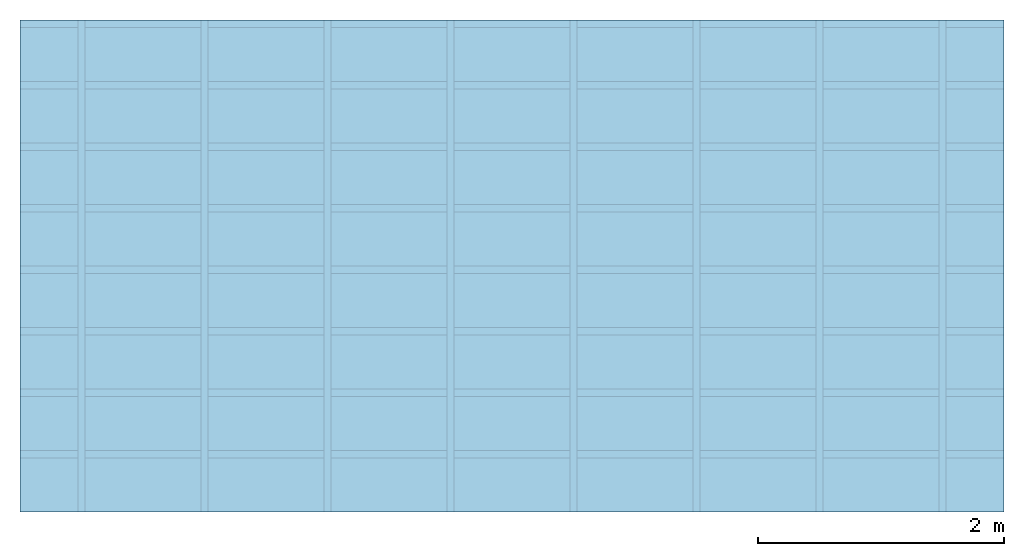
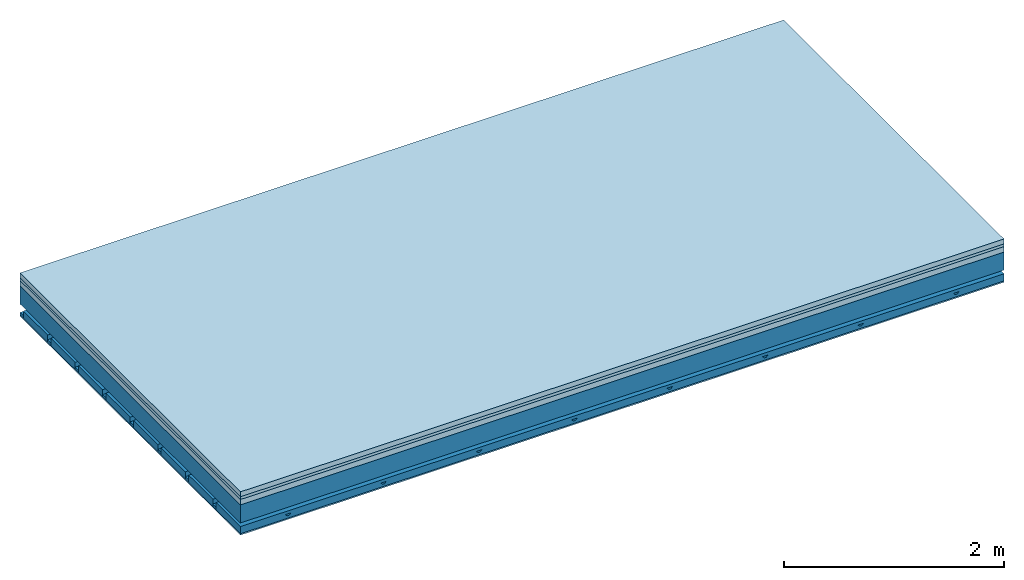
# One storey: 4 members, 4 plates, 1 element without a shape of its own.
"""IFC4 building model written with IfcOpenShell, lengths in metres."""

from ifc_helpers import new_model, si_unit, derived_unit, direction, frame, frame_2d, origin, origin_with_axes, place, context, project, spatial, polyline, rectangle, outline, extrude, material, layer, layer_set, type_object, element, aggregate, save


model = new_model("IFC4")

# Units and contexts
plan_context = context("Plan", 3, precision=1e-05, world=origin(), true_north=direction((0.0, 1.0)))
model_context = context("Model", 3, precision=1e-05, world=origin(), true_north=direction((0.0, 1.0)))
ifc_project = project(units=[si_unit("LENGTHUNIT", "METRE"), derived_unit("SOUNDPRESSUREUNIT", [(si_unit("PRESSUREUNIT", "PASCAL", prefix="MICRO"), 0)]), si_unit("ENERGYUNIT", "JOULE", prefix="MEGA"), si_unit("MASSUNIT", "GRAM", prefix="KILO"), derived_unit("THERMALTRANSMITTANCEUNIT", [(si_unit("POWERUNIT", "WATT"), 1), (si_unit("AREAUNIT", "SQUARE_METRE"), -1), (si_unit("THERMODYNAMICTEMPERATUREUNIT", "KELVIN"), -1)]), derived_unit("AREADENSITYUNIT", [(si_unit("MASSUNIT", "GRAM", prefix="KILO"), 1), (si_unit("AREAUNIT", "SQUARE_METRE"), -1)]), derived_unit("USERDEFINED", [(si_unit("ENERGYUNIT", "JOULE", prefix="MEGA"), 1), (si_unit("AREAUNIT", "SQUARE_METRE"), -1)])], contexts=[plan_context, model_context])

# Site, building, storey
site = spatial("IfcSite", under=ifc_project)
building_placement = place(None, origin())
building = spatial("IfcBuilding", under=site, at=building_placement)
storey_placement = place(building_placement, origin())
storey = spatial("IfcBuildingStorey", under=building, at=storey_placement)

# Slab, members, plates
ifc_material_1 = material(Category="04.005")
ifc_layer_1 = layer(ifc_material_1, 0.055, Name="On-material")
ifc_material_2 = material()
ifc_layer_2 = layer(ifc_material_2, 0.03, Name="Impact sound insulation")
ifc_material_3 = material(Category="03.011")
ifc_layer_3 = layer(ifc_material_3, 0.06, Name="on Supporting structure")
ifc_layer_4 = layer(None, 0.2, Name="Supporting structure")
ifc_material_4 = material(Name="no composite action")
ifc_layer_5 = layer(ifc_material_4, 0.0, Name="Bond")
ifc_layer_6 = layer(None, 0.093, Name="Coupling")
ifc_layer_7 = layer(None, 0.027, Name="Battens / profiles")
ifc_material_5 = material(Category="03.007")
ifc_layer_8 = layer(ifc_material_5, 0.015, Name="Ceiling covering 1st layer")
ifc_material_6 = material(Name="Glued joints")
ifc_layer_9 = layer(ifc_material_6, 0.0, Name="Surface / treatment")
ifc_layer_set = layer_set([ifc_layer_1, ifc_layer_2, ifc_layer_3, ifc_layer_4, ifc_layer_5, ifc_layer_6, ifc_layer_7, ifc_layer_8, ifc_layer_9])
slab_type = type_object("IfcSlabType", Name="A1155", PredefinedType="NOTDEFINED", material=ifc_layer_set)
slab_placement = place(None, frame((0.0, 0.0, 0.0), z_axis=(0.0, 0.0, -1.0), x_axis=(1.0, 0.0, 0.0)))
slab = element("IfcSlab", 1, at=slab_placement, inside=storey, type_object=slab_type, material=ifc_layer_set, Name="Slab #1")
ifc_material_7 = material()
member_1_placement = place(slab_placement, origin())
member_1 = element("IfcMember", 2, at=member_1_placement, material=ifc_material_7, Name="Supporting structure", context=plan_context, shape_type="SweptSolid", body=[
    extrude(rectangle(XDim=1.0, YDim=0.2, at=frame_2d((0.5, 0.1), x_axis=(1.0, 0.0))), frame((0.0, 4.0, 0.145), z_axis=(0.0, -1.0, 0.0), x_axis=(1.0, 0.0, 0.0)), (0.0, 0.0, 1.0), 4.0),
    extrude(rectangle(XDim=1.0, YDim=0.2, at=frame_2d((0.5, 0.1), x_axis=(1.0, 0.0))), frame((1.0, 4.0, 0.145), z_axis=(0.0, -1.0, 0.0), x_axis=(1.0, 0.0, 0.0)), (0.0, 0.0, 1.0), 4.0),
    extrude(rectangle(XDim=1.0, YDim=0.2, at=frame_2d((0.5, 0.1), x_axis=(1.0, 0.0))), frame((2.0, 4.0, 0.145), z_axis=(0.0, -1.0, 0.0), x_axis=(1.0, 0.0, 0.0)), (0.0, 0.0, 1.0), 4.0),
    extrude(rectangle(XDim=1.0, YDim=0.2, at=frame_2d((0.5, 0.1), x_axis=(1.0, 0.0))), frame((3.0, 4.0, 0.145), z_axis=(0.0, -1.0, 0.0), x_axis=(1.0, 0.0, 0.0)), (0.0, 0.0, 1.0), 4.0),
    extrude(rectangle(XDim=1.0, YDim=0.2, at=frame_2d((0.5, 0.1), x_axis=(1.0, 0.0))), frame((4.0, 4.0, 0.145), z_axis=(0.0, -1.0, 0.0), x_axis=(1.0, 0.0, 0.0)), (0.0, 0.0, 1.0), 4.0),
    extrude(rectangle(XDim=1.0, YDim=0.2, at=frame_2d((0.5, 0.1), x_axis=(1.0, 0.0))), frame((5.0, 4.0, 0.145), z_axis=(0.0, -1.0, 0.0), x_axis=(1.0, 0.0, 0.0)), (0.0, 0.0, 1.0), 4.0),
    extrude(rectangle(XDim=1.0, YDim=0.2, at=frame_2d((0.5, 0.1), x_axis=(1.0, 0.0))), frame((6.0, 4.0, 0.145), z_axis=(0.0, -1.0, 0.0), x_axis=(1.0, 0.0, 0.0)), (0.0, 0.0, 1.0), 4.0),
    extrude(rectangle(XDim=1.0, YDim=0.2, at=frame_2d((0.5, 0.1), x_axis=(1.0, 0.0))), frame((7.0, 4.0, 0.145), z_axis=(0.0, -1.0, 0.0), x_axis=(1.0, 0.0, 0.0)), (0.0, 0.0, 1.0), 4.0),
])
ifc_material_8 = material()
member_2_placement = place(slab_placement, origin())
member_2 = element("IfcMember", 3, at=member_2_placement, material=ifc_material_8, Name="Coupling", context=plan_context, shape_type="SweptSolid", body=[
    extrude(outline(polyline([(0.0, 0.0), (0.06, 0.0), (0.04, 0.02), (0.02, 0.02), (0.0, 0.0)])), frame((0.47, 4.0, 0.418), z_axis=(0.0, -1.0, 0.0), x_axis=(1.0, 0.0, 0.0)), (0.0, 0.0, 1.0), 4.0),
    extrude(outline(polyline([(0.0, 0.0), (0.06, 0.0), (0.04, 0.02), (0.02, 0.02), (0.0, 0.0)])), frame((1.47, 4.0, 0.418), z_axis=(0.0, -1.0, 0.0), x_axis=(1.0, 0.0, 0.0)), (0.0, 0.0, 1.0), 4.0),
    extrude(outline(polyline([(0.0, 0.0), (0.06, 0.0), (0.04, 0.02), (0.02, 0.02), (0.0, 0.0)])), frame((2.47, 4.0, 0.418), z_axis=(0.0, -1.0, 0.0), x_axis=(1.0, 0.0, 0.0)), (0.0, 0.0, 1.0), 4.0),
    extrude(outline(polyline([(0.0, 0.0), (0.06, 0.0), (0.04, 0.02), (0.02, 0.02), (0.0, 0.0)])), frame((3.47, 4.0, 0.418), z_axis=(0.0, -1.0, 0.0), x_axis=(1.0, 0.0, 0.0)), (0.0, 0.0, 1.0), 4.0),
    extrude(outline(polyline([(0.0, 0.0), (0.06, 0.0), (0.04, 0.02), (0.02, 0.02), (0.0, 0.0)])), frame((4.47, 4.0, 0.418), z_axis=(0.0, -1.0, 0.0), x_axis=(1.0, 0.0, 0.0)), (0.0, 0.0, 1.0), 4.0),
    extrude(outline(polyline([(0.0, 0.0), (0.06, 0.0), (0.04, 0.02), (0.02, 0.02), (0.0, 0.0)])), frame((5.47, 4.0, 0.418), z_axis=(0.0, -1.0, 0.0), x_axis=(1.0, 0.0, 0.0)), (0.0, 0.0, 1.0), 4.0),
    extrude(outline(polyline([(0.0, 0.0), (0.06, 0.0), (0.04, 0.02), (0.02, 0.02), (0.0, 0.0)])), frame((6.47, 4.0, 0.418), z_axis=(0.0, -1.0, 0.0), x_axis=(1.0, 0.0, 0.0)), (0.0, 0.0, 1.0), 4.0),
    extrude(outline(polyline([(0.0, 0.0), (0.06, 0.0), (0.04, 0.02), (0.02, 0.02), (0.0, 0.0)])), frame((7.47, 4.0, 0.418), z_axis=(0.0, -1.0, 0.0), x_axis=(1.0, 0.0, 0.0)), (0.0, 0.0, 1.0), 4.0),
])
ifc_material_9 = material()
member_3_placement = place(slab_placement, origin())
member_3 = element("IfcMember", 4, at=member_3_placement, material=ifc_material_9, Name="Battens / profiles", context=plan_context, shape_type="SweptSolid", body=[
    extrude(rectangle(XDim=0.06, YDim=0.027, at=frame_2d((0.03, 0.0135), x_axis=(1.0, 0.0))), frame((0.0, 0.0, 0.438), z_axis=(1.0, 0.0, 0.0), x_axis=(0.0, 1.0, 0.0)), (0.0, 0.0, 1.0), 8.0),
    extrude(rectangle(XDim=0.06, YDim=0.027, at=frame_2d((0.03, 0.0135), x_axis=(1.0, 0.0))), frame((0.0, 0.5, 0.438), z_axis=(1.0, 0.0, 0.0), x_axis=(0.0, 1.0, 0.0)), (0.0, 0.0, 1.0), 8.0),
    extrude(rectangle(XDim=0.06, YDim=0.027, at=frame_2d((0.03, 0.0135), x_axis=(1.0, 0.0))), frame((0.0, 1.0, 0.438), z_axis=(1.0, 0.0, 0.0), x_axis=(0.0, 1.0, 0.0)), (0.0, 0.0, 1.0), 8.0),
    extrude(rectangle(XDim=0.06, YDim=0.027, at=frame_2d((0.03, 0.0135), x_axis=(1.0, 0.0))), frame((0.0, 1.5, 0.438), z_axis=(1.0, 0.0, 0.0), x_axis=(0.0, 1.0, 0.0)), (0.0, 0.0, 1.0), 8.0),
    extrude(rectangle(XDim=0.06, YDim=0.027, at=frame_2d((0.03, 0.0135), x_axis=(1.0, 0.0))), frame((0.0, 2.0, 0.438), z_axis=(1.0, 0.0, 0.0), x_axis=(0.0, 1.0, 0.0)), (0.0, 0.0, 1.0), 8.0),
    extrude(rectangle(XDim=0.06, YDim=0.027, at=frame_2d((0.03, 0.0135), x_axis=(1.0, 0.0))), frame((0.0, 2.5, 0.438), z_axis=(1.0, 0.0, 0.0), x_axis=(0.0, 1.0, 0.0)), (0.0, 0.0, 1.0), 8.0),
    extrude(rectangle(XDim=0.06, YDim=0.027, at=frame_2d((0.03, 0.0135), x_axis=(1.0, 0.0))), frame((0.0, 3.0, 0.438), z_axis=(1.0, 0.0, 0.0), x_axis=(0.0, 1.0, 0.0)), (0.0, 0.0, 1.0), 8.0),
    extrude(rectangle(XDim=0.06, YDim=0.027, at=frame_2d((0.03, 0.0135), x_axis=(1.0, 0.0))), frame((0.0, 3.5, 0.438), z_axis=(1.0, 0.0, 0.0), x_axis=(0.0, 1.0, 0.0)), (0.0, 0.0, 1.0), 8.0),
])
ifc_material_10 = material()
member_4_placement = place(slab_placement, origin())
member_4 = element("IfcMember", 5, at=member_4_placement, material=ifc_material_10, Name="Cavity", context=plan_context, shape_type="SweptSolid", body=[
    extrude(rectangle(XDim=0.44, YDim=0.08, at=frame_2d((0.22, 0.04), x_axis=(1.0, 0.0))), frame((0.0, 0.06, 0.385), z_axis=(1.0, 0.0, 0.0), x_axis=(0.0, 1.0, 0.0)), (0.0, 0.0, 1.0), 8.0),
    extrude(rectangle(XDim=0.44, YDim=0.08, at=frame_2d((0.22, 0.04), x_axis=(1.0, 0.0))), frame((0.0, 0.56, 0.385), z_axis=(1.0, 0.0, 0.0), x_axis=(0.0, 1.0, 0.0)), (0.0, 0.0, 1.0), 8.0),
    extrude(rectangle(XDim=0.44, YDim=0.08, at=frame_2d((0.22, 0.04), x_axis=(1.0, 0.0))), frame((0.0, 1.06, 0.385), z_axis=(1.0, 0.0, 0.0), x_axis=(0.0, 1.0, 0.0)), (0.0, 0.0, 1.0), 8.0),
    extrude(rectangle(XDim=0.44, YDim=0.08, at=frame_2d((0.22, 0.04), x_axis=(1.0, 0.0))), frame((0.0, 1.56, 0.385), z_axis=(1.0, 0.0, 0.0), x_axis=(0.0, 1.0, 0.0)), (0.0, 0.0, 1.0), 8.0),
    extrude(rectangle(XDim=0.44, YDim=0.08, at=frame_2d((0.22, 0.04), x_axis=(1.0, 0.0))), frame((0.0, 2.06, 0.385), z_axis=(1.0, 0.0, 0.0), x_axis=(0.0, 1.0, 0.0)), (0.0, 0.0, 1.0), 8.0),
    extrude(rectangle(XDim=0.44, YDim=0.08, at=frame_2d((0.22, 0.04), x_axis=(1.0, 0.0))), frame((0.0, 2.56, 0.385), z_axis=(1.0, 0.0, 0.0), x_axis=(0.0, 1.0, 0.0)), (0.0, 0.0, 1.0), 8.0),
    extrude(rectangle(XDim=0.44, YDim=0.08, at=frame_2d((0.22, 0.04), x_axis=(1.0, 0.0))), frame((0.0, 3.06, 0.385), z_axis=(1.0, 0.0, 0.0), x_axis=(0.0, 1.0, 0.0)), (0.0, 0.0, 1.0), 8.0),
    extrude(rectangle(XDim=0.44, YDim=0.08, at=frame_2d((0.22, 0.04), x_axis=(1.0, 0.0))), frame((0.0, 3.56, 0.385), z_axis=(1.0, 0.0, 0.0), x_axis=(0.0, 1.0, 0.0)), (0.0, 0.0, 1.0), 8.0),
])
plate_1_placement = place(slab_placement, origin())
plate_1 = element("IfcPlate", 6, at=plate_1_placement, material=ifc_material_1, Name="On-material", context=plan_context, shape_type="SweptSolid", body=[
    extrude(rectangle(XDim=8.0, YDim=4.0, at=frame_2d((4.0, 2.0), x_axis=(1.0, 0.0))), origin_with_axes(), (0.0, 0.0, 1.0), 0.055),
])
plate_2_placement = place(slab_placement, origin())
plate_2 = element("IfcPlate", 7, at=plate_2_placement, material=ifc_material_2, Name="Impact sound insulation", context=plan_context, shape_type="SweptSolid", body=[
    extrude(rectangle(XDim=8.0, YDim=4.0, at=frame_2d((4.0, 2.0), x_axis=(1.0, 0.0))), frame((0.0, 0.0, 0.055), z_axis=(0.0, 0.0, 1.0), x_axis=(1.0, 0.0, 0.0)), (0.0, 0.0, 1.0), 0.03),
])
plate_3_placement = place(slab_placement, origin())
plate_3 = element("IfcPlate", 8, at=plate_3_placement, material=ifc_material_3, Name="on Supporting structure", context=plan_context, shape_type="SweptSolid", body=[
    extrude(rectangle(XDim=8.0, YDim=4.0, at=frame_2d((4.0, 2.0), x_axis=(1.0, 0.0))), frame((0.0, 0.0, 0.085), z_axis=(0.0, 0.0, 1.0), x_axis=(1.0, 0.0, 0.0)), (0.0, 0.0, 1.0), 0.06),
])
plate_4_placement = place(slab_placement, origin())
plate_4 = element("IfcPlate", 9, at=plate_4_placement, material=ifc_material_5, Name="Ceiling covering 1st layer", context=plan_context, shape_type="SweptSolid", body=[
    extrude(rectangle(XDim=8.0, YDim=4.0, at=frame_2d((4.0, 2.0), x_axis=(1.0, 0.0))), frame((0.0, 0.0, 0.465), z_axis=(0.0, 0.0, 1.0), x_axis=(1.0, 0.0, 0.0)), (0.0, 0.0, 1.0), 0.015),
])
aggregate(slab, [plate_1, plate_2, plate_3, member_1, member_2, member_3, member_4, plate_4])

save(model, "model.ifc")
